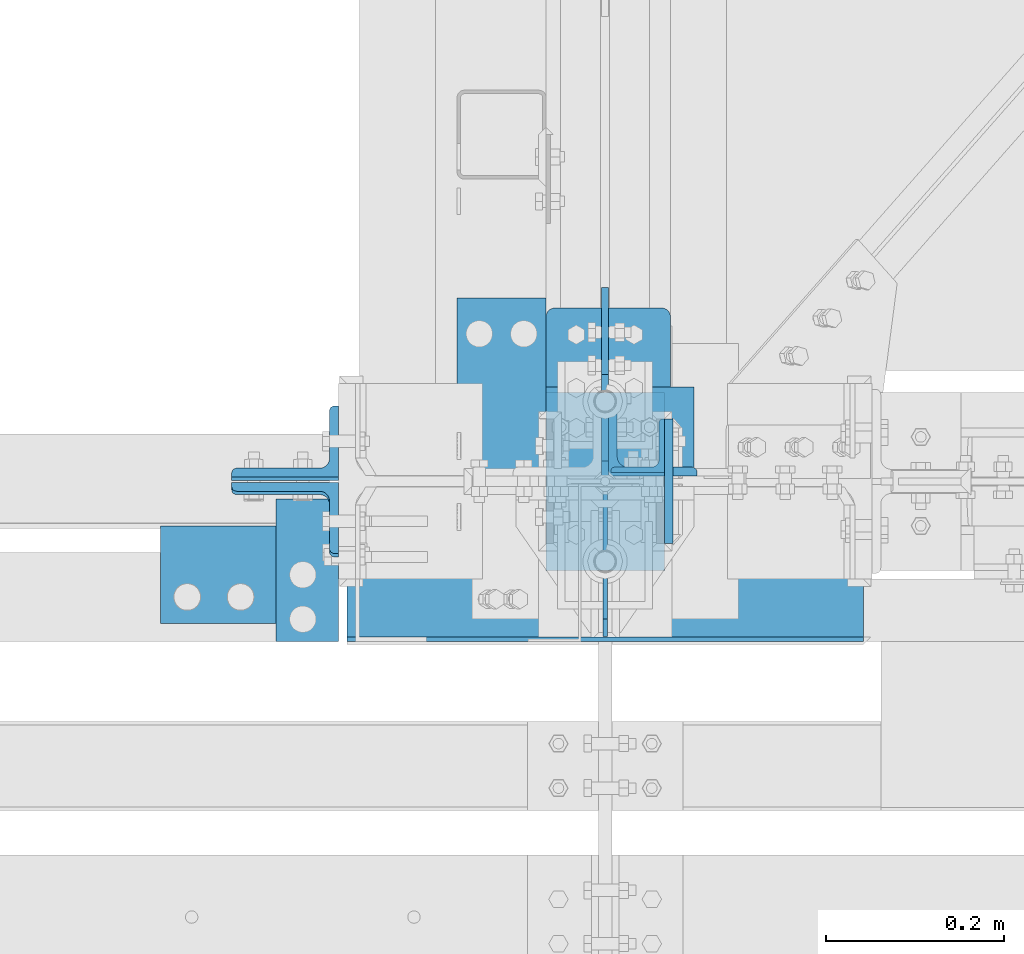
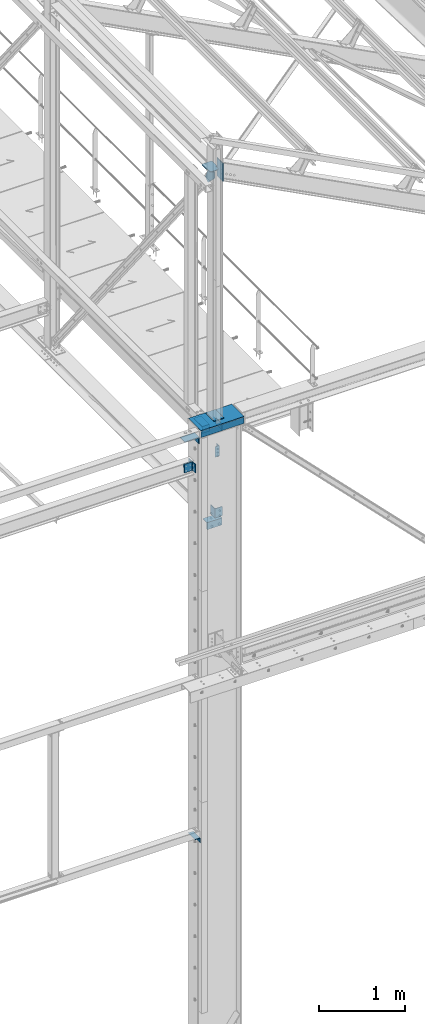
# One storey, part 68 of 496: 13 beams, 2 members, 11 elements without a shape of their own.
"""IFC2X3 building model written with IfcOpenShell, lengths in millimetres."""

from ifc_helpers import new_model, si_unit, frame, frame_2d, origin_with_axes, origin_2d_with_axis, place, context, subcontext, project, spatial, polyline, circle_curve, parameter, trimmed, segment, composite_curve, rectangle, l_section, outline, extrude, material, type_object, element, aggregate, save


model = new_model("IFC2X3")

# Units and contexts
model_context = context("Model", 3, precision=1e-05, world=origin_with_axes())
body_context = subcontext(model_context, "Body", "Model", "MODEL_VIEW")
ifc_project = project(units=[si_unit("LENGTHUNIT", "METRE", prefix="MILLI"), si_unit("AREAUNIT", "SQUARE_METRE"), si_unit("VOLUMEUNIT", "CUBIC_METRE"), si_unit("MASSUNIT", "GRAM", prefix="KILO"), si_unit("TIMEUNIT", "SECOND"), si_unit("PLANEANGLEUNIT", "RADIAN"), si_unit("SOLIDANGLEUNIT", "STERADIAN"), si_unit("THERMODYNAMICTEMPERATUREUNIT", "DEGREE_CELSIUS"), si_unit("LUMINOUSINTENSITYUNIT", "LUMEN")], contexts=[model_context])

# Site, building, storey
site_placement = place(None, origin_with_axes())
site = spatial("IfcSite", under=ifc_project, at=site_placement, CompositionType="ELEMENT")
building_placement = place(site_placement, origin_with_axes())
building = spatial("IfcBuilding", under=site, at=building_placement, Name="Undefined", CompositionType="ELEMENT")
storey_placement = place(building_placement, origin_with_axes())
storey = spatial("IfcBuildingStorey", under=building, at=storey_placement, Name="Undefined", CompositionType="ELEMENT", Elevation=0.0)

# Assembly, beam
assembly_1_placement = place(storey_placement, origin_with_axes())
assembly_1 = element("IfcElementAssembly", 1, at=assembly_1_placement, inside=storey, AssemblyPlace="NOTDEFINED", PredefinedType="NOTDEFINED")
ifc_material = material(Name="Undefined/S235-E24")
beam_type_1 = type_object("IfcBeamType", PredefinedType="NOTDEFINED")
beam_1_placement = place(assembly_1_placement, frame((12716.5083410109, 40.0000004850131, 8100.0), z_axis=(-1.0, 0.0, 0.0), x_axis=(0.0, 0.0, -1.0)))
beam_1 = element("IfcBeam", 2, at=beam_1_placement, type_object=beam_type_1, material=ifc_material, context=body_context, shape_type="SweptSolid", body=[
    extrude(l_section(Depth=60.0, Width=60.0, Thickness=6.0, FilletRadius=8.0, EdgeRadius=4.0, at=origin_2d_with_axis()), frame((149.999995982835, 4.54747350886464e-12, 3.63797880709171e-12), z_axis=(-1.0, 0.0, 0.0), x_axis=(0.0, -1.0, 0.0)), (0.0, 0.0, 1.0), 150.0),
])
aggregate(assembly_1, [beam_1])

assembly_2_placement = place(storey_placement, origin_with_axes())
assembly_2 = element("IfcElementAssembly", 3, at=assembly_2_placement, inside=storey, AssemblyPlace="NOTDEFINED", PredefinedType="NOTDEFINED")
beam_type_2 = type_object("IfcBeamType", PredefinedType="NOTDEFINED")
beam_2_placement = place(assembly_2_placement, frame((12344.9960926457, -180.000008466522, 2725.0), z_axis=(0.0, 0.0, -1.0), x_axis=(0.0, 1.0, 0.0)))
beam_2 = element("IfcBeam", 4, at=beam_2_placement, type_object=beam_type_2, material=ifc_material, context=body_context, shape_type="SweptSolid", body=[
    extrude(l_section(Depth=70.0, Width=70.0, Thickness=7.0, FilletRadius=9.0, EdgeRadius=4.5, at=origin_2d_with_axis()), frame((160.000008264571, 0.0, 0.0), z_axis=(-1.0, 0.0, 0.0), x_axis=(0.0, -1.0, 0.0)), (0.0, 0.0, 1.0), 160.0),
])
aggregate(assembly_2, [beam_2])

assembly_3_placement = place(storey_placement, origin_with_axes())
assembly_3 = element("IfcElementAssembly", 5, at=assembly_3_placement, inside=storey, Name="MONTANT", AssemblyPlace="NOTDEFINED", PredefinedType="NOTDEFINED")
beam_type_3 = type_object("IfcBeamType", PredefinedType="NOTDEFINED")
beam_3_placement = place(assembly_3_placement, frame((12680.0, 100.0, 8555.0), z_axis=(1.0, 0.0, 0.0), x_axis=(0.0, -1.0, 0.0)))
beam_3 = element("IfcBeam", 6, at=beam_3_placement, type_object=beam_type_3, material=ifc_material, context=body_context, shape_type="SweptSolid", body=[
    extrude(rectangle(XDim=10.0, YDim=133.0, at=origin_2d_with_axis()), frame((200.0, 0.0, 0.0), z_axis=(-1.0, 0.0, 0.0), x_axis=(0.0, -1.0, 0.0)), (0.0, 0.0, 1.0), 200.0),
])

assembly_4_placement = place(storey_placement, origin_with_axes())
assembly_4 = element("IfcElementAssembly", 7, at=assembly_4_placement, inside=storey, AssemblyPlace="NOTDEFINED", PredefinedType="NOTDEFINED")
beam_type_4 = type_object("IfcBeamType", PredefinedType="NOTDEFINED")
beam_4_placement = place(assembly_4_placement, frame((12280.0111056914, -49.9898600499616, 8399.99872306502), z_axis=(-0.999999994849078, 0.000101497999992439, 0.0), x_axis=(-0.000101497999992439, -0.999999994849078, 0.0)))
beam_4 = element("IfcBeam", 8, at=beam_4_placement, type_object=beam_type_4, material=ifc_material, context=body_context, shape_type="SweptSolid", body=[
    extrude(l_section(Depth=200.0, Width=100.0, Thickness=10.0, FilletRadius=15.0, EdgeRadius=7.5, at=origin_2d_with_axis()), frame((109.999999008529, 1.81898940354586e-12, 0.0), z_axis=(-1.0, 0.0, 0.0), x_axis=(0.0, -1.0, 0.0)), (0.0, 0.0, 1.0), 110.0),
])
aggregate(assembly_4, [beam_4])

assembly_5_placement = place(storey_placement, origin_with_axes())
assembly_5 = element("IfcElementAssembly", 9, at=assembly_5_placement, inside=storey, AssemblyPlace="NOTDEFINED", PredefinedType="NOTDEFINED")
beam_5_placement = place(assembly_5_placement, frame((12613.5000000138, 106.0, 8400.0), z_axis=(0.0, 1.0, 0.0), x_axis=(-1.0, 0.0, 0.0)))
beam_5 = element("IfcBeam", 10, at=beam_5_placement, type_object=beam_type_4, material=ifc_material, context=body_context, shape_type="SweptSolid", body=[
    extrude(l_section(Depth=200.0, Width=100.0, Thickness=10.0, FilletRadius=15.0, EdgeRadius=7.5, at=origin_2d_with_axis()), frame((100.000000000021, 5.72981662116945e-11, -4.09272615797818e-12), z_axis=(-1.0, 0.0, 0.0), x_axis=(0.0, -1.0, 0.0)), (0.0, 0.0, 1.0), 100.0),
])
aggregate(assembly_5, [beam_5])

assembly_6_placement = place(storey_placement, origin_with_axes())
assembly_6 = element("IfcElementAssembly", 11, at=assembly_6_placement, inside=storey, Name="TRAVERSE SHED", AssemblyPlace="NOTDEFINED", PredefinedType="NOTDEFINED")
beam_type_5 = type_object("IfcBeamType", PredefinedType="NOTDEFINED")
beam_6_placement = place(assembly_6_placement, frame((12751.5, 0.0, 12161.0697488335), z_axis=(0.0, -1.0, 0.0), x_axis=(0.0, 0.0, -1.0)))
beam_6 = element("IfcBeam", 12, at=beam_6_placement, type_object=beam_type_5, material=ifc_material, context=body_context, shape_type="SweptSolid", body=[
    extrude(rectangle(XDim=10.0, YDim=140.0, at=origin_2d_with_axis()), frame((259.795359497664, 0.0, 0.0), z_axis=(-1.0, 0.0, 0.0), x_axis=(0.0, -1.0, 0.0)), (0.0, 0.0, 1.0), 259.8),
])
aggregate(assembly_6, [beam_6])

# Assembly, member
assembly_7_placement = place(storey_placement, origin_with_axes())
assembly_7 = element("IfcElementAssembly", 13, at=assembly_7_placement, inside=storey, AssemblyPlace="NOTDEFINED", PredefinedType="NOTDEFINED")
member_type = type_object("IfcMemberType", PredefinedType="NOTDEFINED")
member_1_placement = place(assembly_7_placement, frame((12319.9978557686, 44.8620356593447, 8008.57381268566), z_axis=(-1.0, 0.0, 0.0), x_axis=(0.0, -0.031410887010906, -0.999506556345274)))
member_1 = element("IfcMember", 14, at=member_1_placement, type_object=member_type, material=ifc_material, context=body_context, shape_type="SweptSolid", body=[
    extrude(l_section(Depth=120.0, Width=80.0, Thickness=10.0, FilletRadius=11.0, EdgeRadius=5.5, at=origin_2d_with_axis()), frame((120.0, 0.0, 0.0), z_axis=(-1.0, 0.0, 0.0), x_axis=(0.0, -1.0, 0.0)), (0.0, 0.0, 1.0), 120.0),
])
aggregate(assembly_7, [member_1])

assembly_8_placement = place(storey_placement, origin_with_axes())
assembly_8 = element("IfcElementAssembly", 15, at=assembly_8_placement, inside=storey, AssemblyPlace="NOTDEFINED", PredefinedType="NOTDEFINED")
member_2_placement = place(assembly_8_placement, frame((12319.9978557687, -44.8657353177814, 7891.33441900945), z_axis=(-1.0, 0.0, 0.0), x_axis=(0.0, 0.031410887010906, 0.999506556345274)))
member_2 = element("IfcMember", 16, at=member_2_placement, type_object=member_type, material=ifc_material, context=body_context, shape_type="SweptSolid", body=[
    extrude(l_section(Depth=120.0, Width=80.0, Thickness=10.0, FilletRadius=11.0, EdgeRadius=5.5, at=origin_2d_with_axis()), frame((120.0, 0.0, 0.0), z_axis=(-1.0, 0.0, 0.0), x_axis=(0.0, -1.0, 0.0)), (0.0, 0.0, 1.0), 120.0),
])
aggregate(assembly_8, [member_2])

# Assembly, beam
assembly_9_placement = place(storey_placement, origin_with_axes())
assembly_9 = element("IfcElementAssembly", 17, at=assembly_9_placement, inside=storey, AssemblyPlace="NOTDEFINED", PredefinedType="NOTDEFINED")
beam_type_6 = type_object("IfcBeamType", PredefinedType="NOTDEFINED")
beam_7_placement = place(assembly_9_placement, frame((12733.4999999862, 56.0023019785509, 7219.99987296137), z_axis=(0.0, 1.0, 0.0), x_axis=(0.0, 0.0, -1.0)))
beam_7 = element("IfcBeam", 18, at=beam_7_placement, type_object=beam_type_6, material=ifc_material, context=body_context, shape_type="SweptSolid", body=[
    extrude(l_section(Depth=100.0, Width=100.0, Thickness=10.0, FilletRadius=12.0, EdgeRadius=6.0, at=origin_2d_with_axis()), frame((130.0, 0.0, 0.0), z_axis=(-1.0, 0.0, 0.0), x_axis=(0.0, -1.0, 0.0)), (0.0, 0.0, 1.0), 130.0),
])
aggregate(assembly_9, [beam_7])

assembly_10_placement = place(storey_placement, origin_with_axes())
assembly_10 = element("IfcElementAssembly", 19, at=assembly_10_placement, inside=storey, AssemblyPlace="NOTDEFINED", PredefinedType="NOTDEFINED")
beam_8_placement = place(assembly_10_placement, frame((12579.9992314794, 56.0030579539932, 7009.99901901354), z_axis=(0.0, 0.0, -1.0), x_axis=(0.999999999883108, 1.52899999980981e-05, 0.0)))
beam_8 = element("IfcBeam", 20, at=beam_8_placement, type_object=beam_type_6, material=ifc_material, context=body_context, shape_type="SweptSolid", body=[
    extrude(l_section(Depth=100.0, Width=100.0, Thickness=10.0, FilletRadius=12.0, EdgeRadius=6.0, at=origin_2d_with_axis()), frame((200.0, 0.0, 0.0), z_axis=(-1.0, 0.0, 0.0), x_axis=(0.0, -1.0, 0.0)), (0.0, 0.0, 1.0), 200.0),
])
aggregate(assembly_10, [beam_8])

# Beam
beam_type_7 = type_object("IfcBeamType", PredefinedType="NOTDEFINED")
beam_9_placement = place(assembly_3_placement, frame((12613.5, 194.999999999999, 12032.0), z_axis=(0.0, 0.0, 1.0), x_axis=(0.0, -1.0, 0.0)))
beam_9 = element("IfcBeam", 21, at=beam_9_placement, type_object=beam_type_7, material=ifc_material, Name="PLAT", context=body_context, shape_type="SweptSolid", body=[
    extrude(outline(composite_curve([segment(trimmed(circle_curve(frame_2d((10.0, 10.0), x_axis=(-1.0, 0.0)), 10.0), [parameter(0.0)], [parameter(1.5707963267949)], True, "PARAMETER"), True, "CONTINUOUS"), segment(polyline([(9.99999999997453, 6.91215973347425e-11), (124.5, 0.0), (124.5, 9.0), (172.25, 9.0), (192.25, 29.0), (192.25, 104.0), (172.25, 124.0), (124.0, 124.0), (124.0, 140.0), (10.0, 140.0)]), True, "CONTINUOUS"), segment(trimmed(circle_curve(frame_2d((10.0, 130.0), x_axis=(0.0, 1.0)), 10.0), [parameter(0.0)], [parameter(1.5707963267949)], True, "PARAMETER"), True, "CONTINUOUS"), segment(polyline([(0.0, 130.0), (-1.81898940354586e-10, 10.0000000000073)]), True, "CONTINUOUS")], self_intersect=True)), frame((0.0, 0.0, -5.0), z_axis=(0.0, 0.0, 1.0), x_axis=(1.0, 0.0, 0.0)), (0.0, 0.0, 1.0), 10.0),
])

beam_type_8 = type_object("IfcBeamType", PredefinedType="NOTDEFINED")
beam_10_placement = place(assembly_3_placement, frame((12680.0, 2.74999999999909, 12027.0), z_axis=(-1.0, 0.0, 0.0), x_axis=(0.0, 1.0, 0.0)))
beam_10 = element("IfcBeam", 22, at=beam_10_placement, type_object=beam_type_8, material=ifc_material, context=body_context, shape_type="SweptSolid", body=[
    extrude(outline(polyline([(0.0, 20.0), (20.0, 0.0), (117.25, 0.0), (215.105651855469, 200.098342895508), (152.447570800781, 249.837310791016), (0.0, 100.0), (0.0, 20.0)])), frame((0.0, 0.0, -4.0), z_axis=(0.0, 0.0, 1.0), x_axis=(1.0, 0.0, 0.0)), (0.0, 0.0, 1.0), 8.0),
])

aggregate(assembly_3, [beam_3, beam_10, beam_9])

# Assembly, beams
assembly_11_placement = place(storey_placement, origin_with_axes())
assembly_11 = element("IfcElementAssembly", 23, at=assembly_11_placement, inside=storey, Name="POTEAU", AssemblyPlace="NOTDEFINED", PredefinedType="NOTDEFINED")
beam_type_9 = type_object("IfcBeamType", PredefinedType="NOTDEFINED")
beam_11_placement = place(assembly_11_placement, frame((12680.0, -6.5, 8450.0), z_axis=(-1.0, 0.0, 0.0), x_axis=(0.0, -1.0, 0.0)))
beam_11 = element("IfcBeam", 24, at=beam_11_placement, type_object=beam_type_9, material=ifc_material, context=body_context, shape_type="SweptSolid", body=[
    extrude(outline(polyline([(0.0, 0.0), (168.0, 0.0), (168.0, 70.0), (148.0, 90.0), (20.000000000001, 90.0), (-7.90371359471465e-08, 70.000007629249), (0.0, 0.0)])), frame((0.0, 0.0, -2.5), z_axis=(0.0, 0.0, 1.0), x_axis=(1.0, 0.0, 0.0)), (0.0, 0.0, 1.0), 5.0),
])
beam_type_10 = type_object("IfcBeamType", PredefinedType="NOTDEFINED")
beam_12_placement = place(assembly_11_placement, frame((12680.0000000043, -177.5, 8540.00000000232), z_axis=(1.0, 0.0, 0.0), x_axis=(0.0, 0.0, -1.0)))
beam_12 = element("IfcBeam", 25, at=beam_12_placement, type_object=beam_type_10, material=ifc_material, context=body_context, shape_type="SweptSolid", body=[
    extrude(rectangle(XDim=5.0, YDim=581.0, at=origin_2d_with_axis()), frame((90.0, 0.0, 0.0), z_axis=(-1.0, 0.0, 0.0), x_axis=(0.0, -1.0, 0.0)), (0.0, 0.0, 1.0), 90.0),
])
beam_type_11 = type_object("IfcBeamType", PredefinedType="NOTDEFINED")
beam_13_placement = place(assembly_11_placement, frame((12389.5, -35.0, 8545.0), z_axis=(0.0, 1.0, 0.0), x_axis=(1.0, 0.0, 0.0)))
beam_13 = element("IfcBeam", 26, at=beam_13_placement, type_object=beam_type_11, material=ifc_material, context=body_context, shape_type="SweptSolid", body=[
    extrude(rectangle(XDim=10.0, YDim=290.0, at=origin_2d_with_axis()), frame((581.0, 0.0, 0.0), z_axis=(-1.0, 0.0, 0.0), x_axis=(0.0, -1.0, 0.0)), (0.0, 0.0, 1.0), 581.0),
])
aggregate(assembly_11, [beam_11, beam_12, beam_13])

save(model, "model.ifc")
